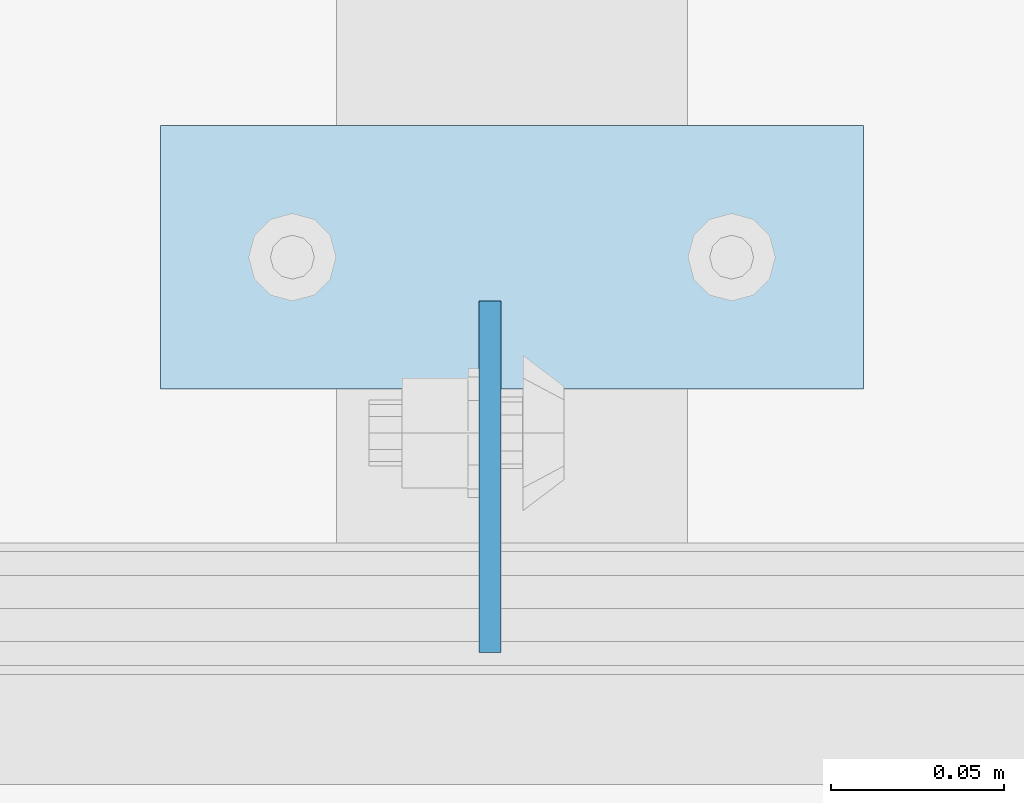
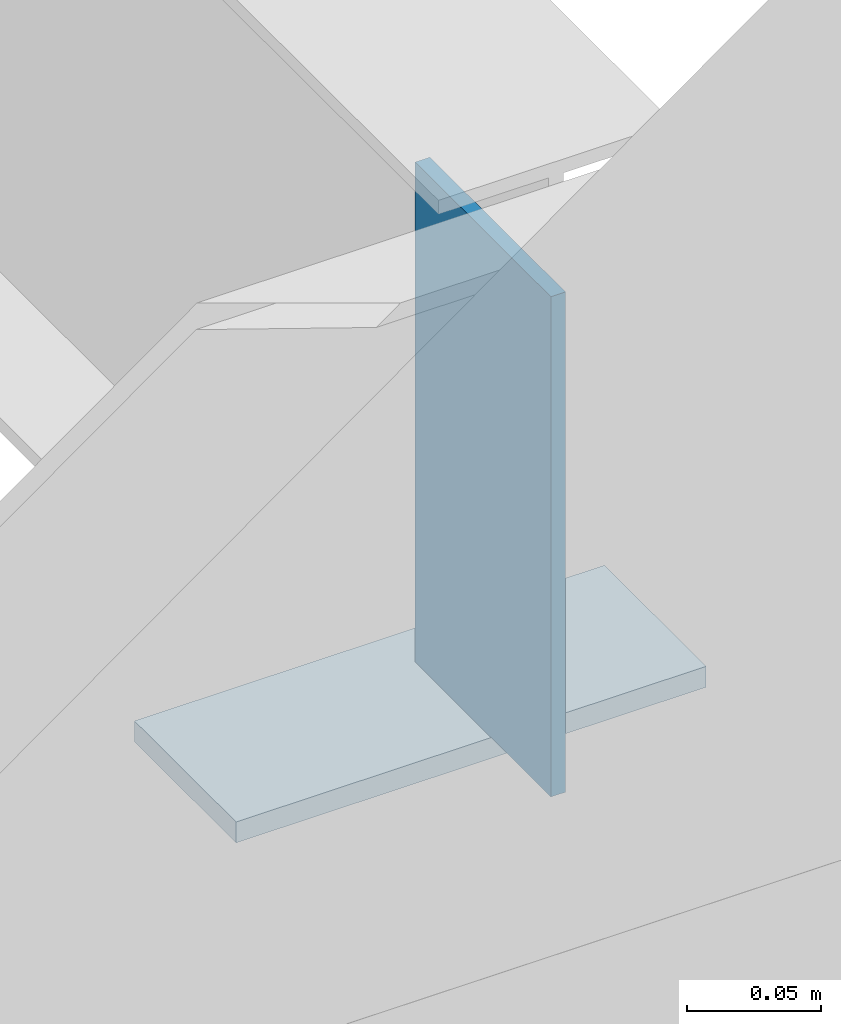
# One storey, part 1499 of 1763: 2 plates, 2 elements without a shape of their own.
"""IFC2X3 building model written with IfcOpenShell, lengths in millimetres."""

from ifc_helpers import new_model, si_unit, frame, origin_with_axes, place, context, subcontext, project, spatial, faceted_brep, material, type_object, element, aggregate, save


model = new_model("IFC2X3")

# Units and contexts
model_context = context("Model", 3, precision=1e-05, world=origin_with_axes())
body_context = subcontext(model_context, "Body", "Model", "MODEL_VIEW")
ifc_project = project(units=[si_unit("LENGTHUNIT", "METRE", prefix="MILLI"), si_unit("AREAUNIT", "SQUARE_METRE"), si_unit("VOLUMEUNIT", "CUBIC_METRE"), si_unit("MASSUNIT", "GRAM", prefix="KILO"), si_unit("TIMEUNIT", "SECOND"), si_unit("PLANEANGLEUNIT", "RADIAN"), si_unit("SOLIDANGLEUNIT", "STERADIAN"), si_unit("THERMODYNAMICTEMPERATUREUNIT", "DEGREE_CELSIUS"), si_unit("LUMINOUSINTENSITYUNIT", "LUMEN")], contexts=[model_context])

# Site, building, storey
site_placement = place(None, origin_with_axes())
site = spatial("IfcSite", under=ifc_project, at=site_placement, CompositionType="ELEMENT")
building_placement = place(site_placement, origin_with_axes())
building = spatial("IfcBuilding", under=site, at=building_placement, Name="Undefined", CompositionType="ELEMENT")
storey_placement = place(building_placement, origin_with_axes())
storey = spatial("IfcBuildingStorey", under=building, at=storey_placement, Name="Undefined", CompositionType="ELEMENT", Elevation=0.0)

# Assembly, plate
assembly_1_placement = place(storey_placement, origin_with_axes())
assembly_1 = element("IfcElementAssembly", 1, at=assembly_1_placement, inside=storey, Name="EMBED PLATE", AssemblyPlace="NOTDEFINED", PredefinedType="RIGID_FRAME")
ifc_material = material(Name="STEEL/A36")
plate_type_1 = type_object("IfcPlateType", PredefinedType="NOTDEFINED")
plate_1_placement = place(assembly_1_placement, frame((-82515.5706070317, 27406.5999969482, 4884.7375), z_axis=(0.0, 1.0, 0.0), x_axis=(1.0, 0.0, 0.0)))
plate_1 = element("IfcPlate", 2, at=plate_1_placement, type_object=plate_type_1, material=ifc_material, Name="EMBED PLATE", context=body_context, shape_type="Brep", body=[
    faceted_brep([(0.0, -4.76249999999982, 0.0), (0.0, -4.76250000000073, 76.1999969482422), (0.0, 4.76250000000073, 76.1999969482422), (0.0, 4.76249999999982, 0.0), (203.199981689453, -4.76249999999982, 76.1999969482422), (203.199981689453, 4.76249999999982, 76.1999969482422), (203.199981689453, -4.76249999999982, 0.0), (203.199981689453, 4.76249999999982, 0.0)], [[[0, 1, 2, 3]], [[1, 4, 5, 2]], [[4, 6, 7, 5]], [[6, 0, 3, 7]], [[5, 7, 3, 2]], [[6, 4, 1, 0]]]),
])
aggregate(assembly_1, [plate_1])

assembly_2_placement = place(storey_placement, origin_with_axes())
assembly_2 = element("IfcElementAssembly", 3, at=assembly_2_placement, inside=storey, Name="BEAM", AssemblyPlace="NOTDEFINED", PredefinedType="RIGID_FRAME")
plate_type_2 = type_object("IfcPlateType", PredefinedType="NOTDEFINED")
plate_2_placement = place(assembly_2_placement, frame((-82420.3206070317, 27330.4, 5143.5), z_axis=(0.0, 1.0, 0.0), x_axis=(0.0, 0.0, -1.0)))
plate_2 = element("IfcPlate", 4, at=plate_2_placement, type_object=plate_type_2, material=ifc_material, Name="PLATE", context=body_context, shape_type="Brep", body=[
    faceted_brep([(1.81898940354586e-12, -3.17500000000291, 0.0), (0.0, -3.17499999999927, 101.599998474121), (0.0, 3.17499999999927, 101.599998474121), (-1.81898940354586e-12, 3.17499999997381, 0.0), (228.600006103516, -3.17499999999927, 101.599998474121), (228.600006103516, 3.17499999999927, 101.599998474121), (228.600006103516, -3.17500000001019, -7.27595761418343e-12), (228.600006103516, 3.17499999999563, -7.27595761418343e-12)], [[[0, 1, 2, 3]], [[1, 4, 5, 2]], [[4, 6, 7, 5]], [[6, 0, 3, 7]], [[5, 7, 3, 2]], [[6, 4, 1, 0]]]),
])
aggregate(assembly_2, [plate_2])

save(model, "model.ifc")
